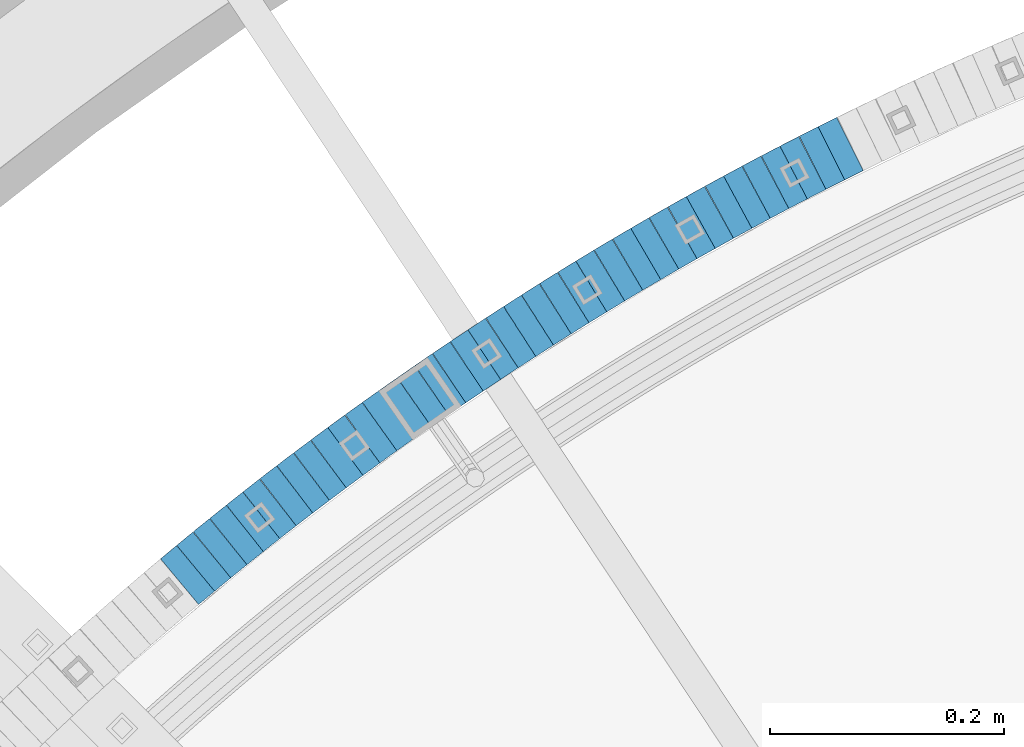
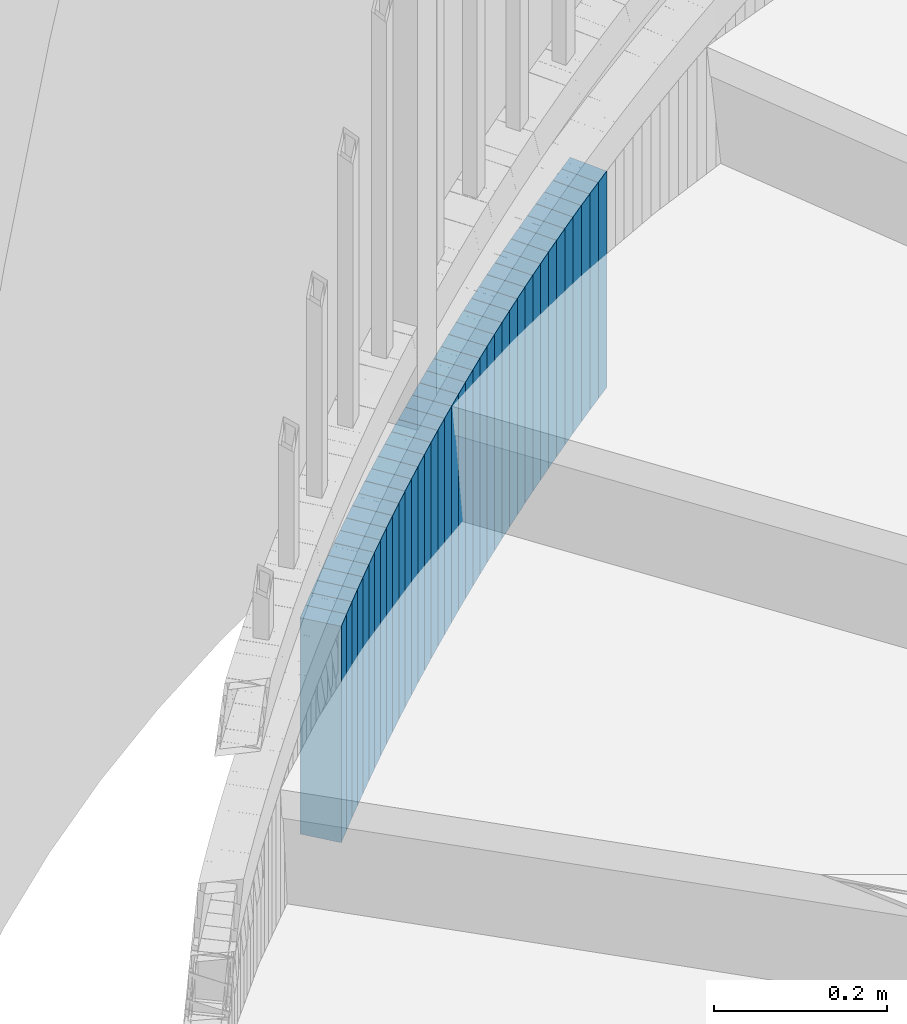
# One storey, part 893 of 975: 38 plates.
"""IFC2X3 building model written with IfcOpenShell, lengths in millimetres."""

from ifc_helpers import new_model, si_unit, frame, origin_with_axes, place, context, subcontext, project, spatial, faceted_brep, material, type_object, element, save


model = new_model("IFC2X3")

# Units and contexts
model_context = context("Model", 3, precision=1e-05, world=origin_with_axes())
body_context = subcontext(model_context, "Body", "Model", "MODEL_VIEW")
ifc_project = project(units=[si_unit("LENGTHUNIT", "METRE", prefix="MILLI"), si_unit("AREAUNIT", "SQUARE_METRE"), si_unit("VOLUMEUNIT", "CUBIC_METRE"), si_unit("MASSUNIT", "GRAM", prefix="KILO"), si_unit("TIMEUNIT", "SECOND"), si_unit("PLANEANGLEUNIT", "RADIAN"), si_unit("SOLIDANGLEUNIT", "STERADIAN"), si_unit("THERMODYNAMICTEMPERATUREUNIT", "DEGREE_CELSIUS"), si_unit("LUMINOUSINTENSITYUNIT", "LUMEN")], contexts=[model_context])

# Site, building, storey
site_placement = place(None, origin_with_axes())
site = spatial("IfcSite", under=ifc_project, at=site_placement, CompositionType="ELEMENT")
building_placement = place(site_placement, origin_with_axes())
building = spatial("IfcBuilding", under=site, at=building_placement, Name="Undefined", CompositionType="ELEMENT")
storey_placement = place(building_placement, origin_with_axes())
storey = spatial("IfcBuildingStorey", under=building, at=storey_placement, Name="Undefined", CompositionType="ELEMENT", Elevation=0.0)

# Plates
ifc_material = material(Name="STEEL/A36")
plate_type = type_object("IfcPlateType", PredefinedType="NOTDEFINED")
plate_1_placement = place(storey_placement, frame((33446.8379005465, 5969.29897554215, 642.299999991737), z_axis=(0.894427191057652, 0.447213595384486, -2.02726596398862e-10), x_axis=(0.0, 0.0, -1.0)))
element("IfcPlate", 1, at=plate_1_placement, inside=storey, type_object=plate_type, material=ifc_material, Name="WALL", context=body_context, shape_type="Brep", body=[
    faceted_brep([(0.0, -25.3999999999724, -1.81898940354586e-11), (-5.80000019073486, -25.4000000000378, 17.8932952880568), (-5.80000019073486, 25.4000000001179, 17.8932952881351), (0.0, 25.3999999999869, 1.45519152283669e-11), (299.0, -25.4000000000378, 17.8932952880568), (299.0, 25.4000000001179, 17.8932952881351), (304.799987792969, -25.3999999999724, -1.81898940354586e-11), (304.799987792969, 25.3999999999869, 1.45519152283669e-11)], [[[0, 1, 2, 3]], [[1, 4, 5, 2]], [[4, 6, 7, 5]], [[6, 0, 3, 7]], [[5, 7, 3, 2]], [[6, 4, 1, 0]]]),
])
for number, where, z_axis, x_axis, name in (
    (2, (33430.8379005525, 5961.29897554183, 636.599999991737), (0.894427191057652, 0.447213595384486, -2.02726596398862e-10), (0.0, 0.0, -1.0), "WALL"),
    (3, (33414.6548294389, 5952.95522164706, 630.899999991737), (0.88876758866203, 0.458358127825701, 0.0), (0.0, 0.0, -1.0), "WALL"),
):
    element("IfcPlate", number, at=place(storey_placement, frame(where, z_axis=z_axis, x_axis=x_axis)), inside=storey, type_object=plate_type, material=ifc_material, Name=name, context=body_context, shape_type="Brep", body=[
        faceted_brep([(0.0, -25.3999999999724, -1.81898940354586e-11), (-5.69999980926514, -25.4000000000087, 17.8910598754701), (-5.69999980926514, 25.4000000000087, 17.8910598755028), (0.0, 25.3999999999869, 1.45519152283669e-11), (299.100006103516, -25.4000000000087, 17.8910598754701), (299.100006103516, 25.4000000000087, 17.8910598755028), (304.799987792969, -25.3999999999724, -1.81898940354586e-11), (304.799987792969, 25.3999999999869, 1.45519152283669e-11)], [[[0, 1, 2, 3]], [[1, 4, 5, 2]], [[4, 6, 7, 5]], [[6, 0, 3, 7]], [[5, 7, 3, 2]], [[6, 4, 1, 0]]]),
    ])
plate_2_placement = place(storey_placement, frame((33398.7967408327, 5944.72516926029, 625.199999991737), z_axis=(0.887584423987997, 0.460645080614019, 2.15857426155708e-10), x_axis=(0.0, 0.0, -1.0)))
element("IfcPlate", 4, at=plate_2_placement, inside=storey, type_object=plate_type, material=ifc_material, Name="WALL", context=body_context, shape_type="Brep", body=[
    faceted_brep([(0.0, -25.3999999999724, -1.81898940354586e-11), (-5.69999980926514, -25.4000000000378, 17.8044929504049), (-5.69999980926514, 25.4000000000233, 17.8044929504613), (0.0, 25.3999999999869, 1.45519152283669e-11), (299.100006103516, -25.4000000000378, 17.8044929504049), (299.100006103516, 25.4000000000233, 17.8044929504613), (304.799987792969, -25.3999999999724, -1.81898940354586e-11), (304.799987792969, 25.3999999999869, 1.45519152283669e-11)], [[[0, 1, 2, 3]], [[1, 4, 5, 2]], [[4, 6, 7, 5]], [[6, 0, 3, 7]], [[5, 7, 3, 2]], [[6, 4, 1, 0]]]),
])
plate_3_placement = place(storey_placement, frame((33382.7736647993, 5936.20798742854, 619.399999991737), z_axis=(0.882970965834001, 0.469427601973053, -3.50903519574786e-11), x_axis=(0.0, 0.0, -1.0)))
element("IfcPlate", 5, at=plate_3_placement, inside=storey, type_object=plate_type, material=ifc_material, Name="WALL", context=body_context, shape_type="Brep", body=[
    faceted_brep([(0.0, -25.3999999999724, -1.81898940354586e-11), (-5.80000019073486, -25.4000000000378, 17.8932952880568), (-5.80000019073486, 25.4000000001179, 17.8932952881351), (0.0, 25.3999999999869, 1.45519152283669e-11), (299.0, -25.4000000000378, 17.8932952880568), (299.0, 25.4000000001179, 17.8932952881351), (304.799987792969, -25.3999999999724, -1.81898940354586e-11), (304.799987792969, 25.3999999999869, 1.45519152283669e-11)], [[[0, 1, 2, 3]], [[1, 4, 5, 2]], [[4, 6, 7, 5]], [[6, 0, 3, 7]], [[5, 7, 3, 2]], [[6, 4, 1, 0]]]),
])
for number, where, z_axis, x_axis, name in (
    (6, (33366.9041173823, 5927.617022949, 613.699999991737), (0.879389687135148, 0.476102697073169, 0.0), (0.0, 0.0, -1.0), "WALL"),
    (7, (33351.204117377, 5919.11702294876, 607.999999991737), (0.879389687135148, 0.476102697073169, 0.0), (0.0, 0.0, -1.0), "WALL"),
):
    element("IfcPlate", number, at=place(storey_placement, frame(where, z_axis=z_axis, x_axis=x_axis)), inside=storey, type_object=plate_type, material=ifc_material, Name=name, context=body_context, shape_type="Brep", body=[
        faceted_brep([(0.0, -25.3999999999724, -1.81898940354586e-11), (-5.69999980926514, -25.3999999999578, 17.853290557905), (-5.69999980926514, 25.4000000000124, 17.8532905578759), (0.0, 25.3999999999869, 1.45519152283669e-11), (299.100006103516, -25.3999999999578, 17.853290557905), (299.100006103516, 25.4000000000124, 17.8532905578759), (304.799987792969, -25.3999999999724, -1.81898940354586e-11), (304.799987792969, 25.3999999999869, 1.45519152283669e-11)], [[[0, 1, 2, 3]], [[1, 4, 5, 2]], [[4, 6, 7, 5]], [[6, 0, 3, 7]], [[5, 7, 3, 2]], [[6, 4, 1, 0]]]),
    ])
plate_4_placement = place(storey_placement, frame((33335.325590683, 5910.26396729605, 602.299999991737), z_axis=(0.87336387405012, 0.48706831502795, 0.0), x_axis=(0.0, 0.0, -1.0)))
element("IfcPlate", 8, at=plate_4_placement, inside=storey, type_object=plate_type, material=ifc_material, Name="WALL", context=body_context, shape_type="Brep", body=[
    faceted_brep([(0.0, -25.3999999999724, -1.81898940354586e-11), (-5.69999980926514, -25.3999999999687, 17.8619709015074), (-5.69999980926514, 25.4000000000415, 17.8619709015402), (0.0, 25.3999999999869, 1.45519152283669e-11), (299.100006103516, -25.3999999999687, 17.8619709015074), (299.100006103516, 25.4000000000415, 17.8619709015402), (304.799987792969, -25.3999999999724, -1.81898940354586e-11), (304.799987792969, 25.3999999999869, 1.45519152283669e-11)], [[[0, 1, 2, 3]], [[1, 4, 5, 2]], [[4, 6, 7, 5]], [[6, 0, 3, 7]], [[5, 7, 3, 2]], [[6, 4, 1, 0]]]),
])
plate_5_placement = place(storey_placement, frame((33319.7255906851, 5901.56396729572, 596.499999991737), z_axis=(0.87336387405012, 0.48706831502795, 0.0), x_axis=(0.0, 0.0, -1.0)))
element("IfcPlate", 9, at=plate_5_placement, inside=storey, type_object=plate_type, material=ifc_material, Name="WALL", context=body_context, shape_type="Brep", body=[
    faceted_brep([(0.0, -25.3999999999724, -1.81898940354586e-11), (-5.80000019073486, -25.3999999999978, 17.8619709014965), (-5.80000019073486, 25.4000000000524, 17.8619709015475), (0.0, 25.3999999999869, 1.45519152283669e-11), (299.0, -25.3999999999978, 17.8619709014965), (299.0, 25.4000000000524, 17.8619709015475), (304.799987792969, -25.3999999999724, -1.81898940354586e-11), (304.799987792969, 25.3999999999869, 1.45519152283669e-11)], [[[0, 1, 2, 3]], [[1, 4, 5, 2]], [[4, 6, 7, 5]], [[6, 0, 3, 7]], [[5, 7, 3, 2]], [[6, 4, 1, 0]]]),
])
plate_6_placement = place(storey_placement, frame((33303.9493116068, 5892.50761716658, 590.799999991737), z_axis=(0.86720835715133, 0.497945444086892, 0.0), x_axis=(0.0, 0.0, -1.0)))
element("IfcPlate", 10, at=plate_6_placement, inside=storey, type_object=plate_type, material=ifc_material, Name="WALL", context=body_context, shape_type="Brep", body=[
    faceted_brep([(0.0, -25.3999999999724, -1.81898940354586e-11), (-5.69999980926514, -25.4000000000524, 17.8734436034756), (-5.69999980926514, 25.4000000000888, 17.8734436035884), (0.0, 25.3999999999869, 1.45519152283669e-11), (299.100006103516, -25.4000000000524, 17.8734436034756), (299.100006103516, 25.4000000000888, 17.8734436035884), (304.799987792969, -25.3999999999724, -1.81898940354586e-11), (304.799987792969, 25.3999999999869, 1.45519152283669e-11)], [[[0, 1, 2, 3]], [[1, 4, 5, 2]], [[4, 6, 7, 5]], [[6, 0, 3, 7]], [[5, 7, 3, 2]], [[6, 4, 1, 0]]]),
])
plate_7_placement = place(storey_placement, frame((33288.3810982039, 5883.41017227856, 585.099999991737), z_axis=(0.863371944159825, 0.504568019237926, -8.114466254483e-11), x_axis=(0.0, 0.0, -1.0)))
element("IfcPlate", 11, at=plate_7_placement, inside=storey, type_object=plate_type, material=ifc_material, Name="WALL", context=body_context, shape_type="Brep", body=[
    faceted_brep([(0.0, -25.3999999999724, -1.81898940354586e-11), (-5.69999980926514, -25.3999999999614, 17.8370399475461), (-5.69999980926514, 25.4000000000487, 17.8370399475571), (0.0, 25.3999999999869, 1.45519152283669e-11), (299.100006103516, -25.3999999999614, 17.8370399475461), (299.100006103516, 25.4000000000487, 17.8370399475571), (304.799987792969, -25.3999999999724, -1.81898940354586e-11), (304.799987792969, 25.3999999999869, 1.45519152283669e-11)], [[[0, 1, 2, 3]], [[1, 4, 5, 2]], [[4, 6, 7, 5]], [[6, 0, 3, 7]], [[5, 7, 3, 2]], [[6, 4, 1, 0]]]),
])
plate_8_placement = place(storey_placement, frame((33272.981098207, 5874.41017227898, 579.299999991737), z_axis=(0.863371944159825, 0.504568019237926, -8.114466254483e-11), x_axis=(0.0, 0.0, -1.0)))
element("IfcPlate", 12, at=plate_8_placement, inside=storey, type_object=plate_type, material=ifc_material, Name="WALL", context=body_context, shape_type="Brep", body=[
    faceted_brep([(0.0, -25.3999999999724, -1.81898940354586e-11), (-5.80000019073486, -25.3999999999578, 17.8370399475461), (-5.80000019073486, 25.4000000000524, 17.8370399475607), (0.0, 25.3999999999869, 1.45519152283669e-11), (299.0, -25.3999999999578, 17.8370399475461), (299.0, 25.4000000000524, 17.8370399475607), (304.799987792969, -25.3999999999724, -1.81898940354586e-11), (304.799987792969, 25.3999999999869, 1.45519152283669e-11)], [[[0, 1, 2, 3]], [[1, 4, 5, 2]], [[4, 6, 7, 5]], [[6, 0, 3, 7]], [[5, 7, 3, 2]], [[6, 4, 1, 0]]]),
])
plate_9_placement = place(storey_placement, frame((33257.3706024892, 5865.08579233509, 573.599999991737), z_axis=(0.858475095883078, 0.512855252238427, -1.68183078130824e-10), x_axis=(0.0, 0.0, -1.0)))
element("IfcPlate", 13, at=plate_9_placement, inside=storey, type_object=plate_type, material=ifc_material, Name="WALL", context=body_context, shape_type="Brep", body=[
    faceted_brep([(0.0, -25.3999999999724, -1.81898940354586e-11), (-5.69999980926514, -25.399999999885, 17.9387855530204), (-5.69999980926514, 25.3999999999651, 17.9387855529603), (0.0, 25.3999999999869, 1.45519152283669e-11), (299.100006103516, -25.399999999885, 17.9387855530204), (299.100006103516, 25.3999999999651, 17.9387855529603), (304.799987792969, -25.3999999999724, -1.81898940354586e-11), (304.799987792969, 25.3999999999869, 1.45519152283669e-11)], [[[0, 1, 2, 3]], [[1, 4, 5, 2]], [[4, 6, 7, 5]], [[6, 0, 3, 7]], [[5, 7, 3, 2]], [[6, 4, 1, 0]]]),
])
plate_10_placement = place(storey_placement, frame((33241.9039773167, 5855.68538220351, 567.899999991737), z_axis=(0.854521941236345, 0.519415298143661, 0.0), x_axis=(0.0, 0.0, -1.0)))
element("IfcPlate", 14, at=plate_10_placement, inside=storey, type_object=plate_type, material=ifc_material, Name="WALL", context=body_context, shape_type="Brep", body=[
    faceted_brep([(0.0, -25.3999999999724, -1.81898940354586e-11), (-5.69999980926514, -25.3999999999578, 17.9047489166387), (-5.69999980926514, 25.3999999999069, 17.9047489165732), (0.0, 25.3999999999869, 1.45519152283669e-11), (299.100006103516, -25.3999999999578, 17.9047489166387), (299.100006103516, 25.3999999999069, 17.9047489165732), (304.799987792969, -25.3999999999724, -1.81898940354586e-11), (304.799987792969, 25.3999999999869, 1.45519152283669e-11)], [[[0, 1, 2, 3]], [[1, 4, 5, 2]], [[4, 6, 7, 5]], [[6, 0, 3, 7]], [[5, 7, 3, 2]], [[6, 4, 1, 0]]]),
])
plate_11_placement = place(storey_placement, frame((33226.6407660649, 5846.34683340255, 562.099999991737), z_axis=(0.853004272179022, 0.521903929516091, -1.64764969667885e-10), x_axis=(0.0, 0.0, -1.0)))
element("IfcPlate", 15, at=plate_11_placement, inside=storey, type_object=plate_type, material=ifc_material, Name="WALL", context=body_context, shape_type="Brep", body=[
    faceted_brep([(0.0, -25.3999999999724, -1.81898940354586e-11), (-5.80000019073486, -25.400000000016, 17.8193721771022), (-5.80000019073486, 25.4000000001179, 17.8193721772113), (0.0, 25.3999999999869, 1.45519152283669e-11), (299.0, -25.400000000016, 17.8193721771022), (299.0, 25.4000000001179, 17.8193721772113), (304.799987792969, -25.3999999999724, -1.81898940354586e-11), (304.799987792969, 25.3999999999869, 1.45519152283669e-11)], [[[0, 1, 2, 3]], [[1, 4, 5, 2]], [[4, 6, 7, 5]], [[6, 0, 3, 7]], [[5, 7, 3, 2]], [[6, 4, 1, 0]]]),
])
plate_12_placement = place(storey_placement, frame((33211.2351528119, 5836.71968181761, 556.399999991737), z_axis=(0.847998304005088, 0.529998940003181, 0.0), x_axis=(0.0, 0.0, -1.0)))
element("IfcPlate", 16, at=plate_12_placement, inside=storey, type_object=plate_type, material=ifc_material, Name="WALL", context=body_context, shape_type="Brep", body=[
    faceted_brep([(0.0, -25.3999999999724, -1.81898940354586e-11), (-5.69999980926514, -25.4000000000087, 17.9245643615468), (-5.69999980926514, 25.3999999999687, 17.9245643615541), (0.0, 25.3999999999869, 1.45519152283669e-11), (299.100006103516, -25.4000000000087, 17.9245643615468), (299.100006103516, 25.3999999999687, 17.9245643615541), (304.799987792969, -25.3999999999724, -1.81898940354586e-11), (304.799987792969, 25.3999999999869, 1.45519152283669e-11)], [[[0, 1, 2, 3]], [[1, 4, 5, 2]], [[4, 6, 7, 5]], [[6, 0, 3, 7]], [[5, 7, 3, 2]], [[6, 4, 1, 0]]]),
])
plate_13_placement = place(storey_placement, frame((33195.969674812, 5827.01536982686, 550.599999991737), z_axis=(0.843891532718926, 0.536513821821304, 0.0), x_axis=(0.0, 0.0, -1.0)))
element("IfcPlate", 17, at=plate_13_placement, inside=storey, type_object=plate_type, material=ifc_material, Name="WALL", context=body_context, shape_type="Brep", body=[
    faceted_brep([(0.0, -25.3999999999724, -1.81898940354586e-11), (-5.80000019073486, -25.4000000000378, 17.8932952880568), (-5.80000019073486, 25.4000000001179, 17.8932952881351), (0.0, 25.3999999999869, 1.45519152283669e-11), (299.0, -25.4000000000378, 17.8932952880568), (299.0, 25.4000000001179, 17.8932952881351), (304.799987792969, -25.3999999999724, -1.81898940354586e-11), (304.799987792969, 25.3999999999869, 1.45519152283669e-11)], [[[0, 1, 2, 3]], [[1, 4, 5, 2]], [[4, 6, 7, 5]], [[6, 0, 3, 7]], [[5, 7, 3, 2]], [[6, 4, 1, 0]]]),
])
plate_14_placement = place(storey_placement, frame((33180.769036802, 5817.25105531003, 544.899999991737), z_axis=(0.84135946512133, 0.540475948077942, 0.0), x_axis=(0.0, 0.0, -1.0)))
element("IfcPlate", 18, at=plate_14_placement, inside=storey, type_object=plate_type, material=ifc_material, Name="WALL", context=body_context, shape_type="Brep", body=[
    faceted_brep([(0.0, -25.3999999999724, -1.81898940354586e-11), (-5.69999980926514, -25.4000000000087, 17.9493732452502), (-5.69999980926514, 25.3999999999905, 17.9493732452102), (0.0, 25.3999999999869, 1.45519152283669e-11), (299.100006103516, -25.4000000000087, 17.9493732452502), (299.100006103516, 25.3999999999905, 17.9493732452102), (304.799987792969, -25.3999999999724, -1.81898940354586e-11), (304.799987792969, 25.3999999999869, 1.45519152283669e-11)], [[[0, 1, 2, 3]], [[1, 4, 5, 2]], [[4, 6, 7, 5]], [[6, 0, 3, 7]], [[5, 7, 3, 2]], [[6, 4, 1, 0]]]),
])
plate_15_placement = place(storey_placement, frame((33165.7044397314, 5807.50942099266, 539.199999991737), z_axis=(0.83972031877, 0.543019139851267, 0.0), x_axis=(0.0, 0.0, -1.0)))
element("IfcPlate", 19, at=plate_15_placement, inside=storey, type_object=plate_type, material=ifc_material, Name="WALL", context=body_context, shape_type="Brep", body=[
    faceted_brep([(0.0, -25.3999999999724, -1.81898940354586e-11), (-5.69999980926514, -25.3999999999687, 17.8619709015074), (-5.69999980926514, 25.4000000000415, 17.8619709015402), (0.0, 25.3999999999869, 1.45519152283669e-11), (299.100006103516, -25.3999999999687, 17.8619709015074), (299.100006103516, 25.4000000000415, 17.8619709015402), (304.799987792969, -25.3999999999724, -1.81898940354586e-11), (304.799987792969, 25.3999999999869, 1.45519152283669e-11)], [[[0, 1, 2, 3]], [[1, 4, 5, 2]], [[4, 6, 7, 5]], [[6, 0, 3, 7]], [[5, 7, 3, 2]], [[6, 4, 1, 0]]]),
])
plate_16_placement = place(storey_placement, frame((33150.5057338021, 5797.47960382964, 533.399999991737), z_axis=(0.834609406352343, 0.550842208647984, 2.89660420094152e-10), x_axis=(0.0, 0.0, -1.0)))
element("IfcPlate", 20, at=plate_16_placement, inside=storey, type_object=plate_type, material=ifc_material, Name="WALL", context=body_context, shape_type="Brep", body=[
    faceted_brep([(0.0, -25.3999999999724, -1.81898940354586e-11), (-5.80000019073486, -25.4000000000051, 17.9724788665662), (-5.80000019073486, 25.4000000000196, 17.9724788666281), (0.0, 25.3999999999869, 1.45519152283669e-11), (299.0, -25.4000000000051, 17.9724788665662), (299.0, 25.4000000000196, 17.9724788666281), (304.799987792969, -25.3999999999724, -1.81898940354586e-11), (304.799987792969, 25.3999999999869, 1.45519152283669e-11)], [[[0, 1, 2, 3]], [[1, 4, 5, 2]], [[4, 6, 7, 5]], [[6, 0, 3, 7]], [[5, 7, 3, 2]], [[6, 4, 1, 0]]]),
])
plate_17_placement = place(storey_placement, frame((33135.5405238058, 5787.53642095245, 527.599999991737), z_axis=(0.832909293569711, 0.553409530714104, 0.0), x_axis=(0.0, 0.0, -1.0)))
element("IfcPlate", 21, at=plate_17_placement, inside=storey, type_object=plate_type, material=ifc_material, Name="WALL", context=body_context, shape_type="Brep", body=[
    faceted_brep([(0.0, -25.3999999999724, -1.81898940354586e-11), (-5.80000019073486, -25.4000000000378, 17.8932952880568), (-5.80000019073486, 25.4000000001179, 17.8932952881351), (0.0, 25.3999999999869, 1.45519152283669e-11), (299.0, -25.4000000000378, 17.8932952880568), (299.0, 25.4000000001179, 17.8932952881351), (304.799987792969, -25.3999999999724, -1.81898940354586e-11), (304.799987792969, 25.3999999999869, 1.45519152283669e-11)], [[[0, 1, 2, 3]], [[1, 4, 5, 2]], [[4, 6, 7, 5]], [[6, 0, 3, 7]], [[5, 7, 3, 2]], [[6, 4, 1, 0]]]),
])
plate_18_placement = place(storey_placement, frame((33120.5424790931, 5777.47094864982, 521.899999991737), z_axis=(0.830331643827375, 0.557269558884145, 0.0), x_axis=(0.0, 0.0, -1.0)))
element("IfcPlate", 22, at=plate_18_placement, inside=storey, type_object=plate_type, material=ifc_material, Name="WALL", context=body_context, shape_type="Brep", body=[
    faceted_brep([(0.0, -25.3999999999724, -1.81898940354586e-11), (-5.69999980926514, -25.399999999885, 17.9387855530204), (-5.69999980926514, 25.3999999999651, 17.9387855529603), (0.0, 25.3999999999869, 1.45519152283669e-11), (299.100006103516, -25.399999999885, 17.9387855530204), (299.100006103516, 25.3999999999651, 17.9387855529603), (304.799987792969, -25.3999999999724, -1.81898940354586e-11), (304.799987792969, 25.3999999999869, 1.45519152283669e-11)], [[[0, 1, 2, 3]], [[1, 4, 5, 2]], [[4, 6, 7, 5]], [[6, 0, 3, 7]], [[5, 7, 3, 2]], [[6, 4, 1, 0]]]),
])
plate_19_placement = place(storey_placement, frame((33105.5795744149, 5767.26069934168, 516.199999991737), z_axis=(0.825991119591471, 0.56368312938745, 1.78134541783948e-10), x_axis=(0.0, 0.0, -1.0)))
element("IfcPlate", 23, at=plate_19_placement, inside=storey, type_object=plate_type, material=ifc_material, Name="WALL", context=body_context, shape_type="Brep", body=[
    faceted_brep([(0.0, -25.3999999999724, -1.81898940354586e-11), (-5.69999980926514, -25.4000000000087, 17.9245643615468), (-5.69999980926514, 25.3999999999687, 17.9245643615541), (0.0, 25.3999999999869, 1.45519152283669e-11), (299.100006103516, -25.4000000000087, 17.9245643615468), (299.100006103516, 25.3999999999687, 17.9245643615541), (304.799987792969, -25.3999999999724, -1.81898940354586e-11), (304.799987792969, 25.3999999999869, 1.45519152283669e-11)], [[[0, 1, 2, 3]], [[1, 4, 5, 2]], [[4, 6, 7, 5]], [[6, 0, 3, 7]], [[5, 7, 3, 2]], [[6, 4, 1, 0]]]),
])
plate_20_placement = place(storey_placement, frame((33090.7170545739, 5756.94886298745, 510.399999991737), z_axis=(0.821588113548792, 0.570081548267734, 1.52022039401345e-10), x_axis=(0.0, 0.0, -1.0)))
element("IfcPlate", 24, at=plate_20_placement, inside=storey, type_object=plate_type, material=ifc_material, Name="WALL", context=body_context, shape_type="Brep", body=[
    faceted_brep([(0.0, -25.3999999999724, -1.81898940354586e-11), (-5.80000019073486, -25.4000000000378, 17.8932952880568), (-5.80000019073486, 25.4000000001179, 17.8932952881351), (0.0, 25.3999999999869, 1.45519152283669e-11), (299.0, -25.4000000000378, 17.8932952880568), (299.0, 25.4000000001179, 17.8932952881351), (304.799987792969, -25.3999999999724, -1.81898940354586e-11), (304.799987792969, 25.3999999999869, 1.45519152283669e-11)], [[[0, 1, 2, 3]], [[1, 4, 5, 2]], [[4, 6, 7, 5]], [[6, 0, 3, 7]], [[5, 7, 3, 2]], [[6, 4, 1, 0]]]),
])
plate_21_placement = place(storey_placement, frame((33075.9216866142, 5746.58236543765, 504.699999991737), z_axis=(0.818970100023311, 0.573836192016335, 0.0), x_axis=(0.0, 0.0, -1.0)))
element("IfcPlate", 25, at=plate_21_placement, inside=storey, type_object=plate_type, material=ifc_material, Name="WALL", context=body_context, shape_type="Brep", body=[
    faceted_brep([(0.0, -25.3999999999724, -1.81898940354586e-11), (-5.69999980926514, -25.4000000000087, 17.9493732452502), (-5.69999980926514, 25.3999999999905, 17.9493732452102), (0.0, 25.3999999999869, 1.45519152283669e-11), (299.100006103516, -25.4000000000087, 17.9493732452502), (299.100006103516, 25.3999999999905, 17.9493732452102), (304.799987792969, -25.3999999999724, -1.81898940354586e-11), (304.799987792969, 25.3999999999869, 1.45519152283669e-11)], [[[0, 1, 2, 3]], [[1, 4, 5, 2]], [[4, 6, 7, 5]], [[6, 0, 3, 7]], [[5, 7, 3, 2]], [[6, 4, 1, 0]]]),
])
plate_22_placement = place(storey_placement, frame((33061.1604959829, 5736.06848610545, 498.899999991737), z_axis=(0.814486661793431, 0.580182279771275, -2.11284714168869e-11), x_axis=(0.0, 0.0, -1.0)))
element("IfcPlate", 26, at=plate_22_placement, inside=storey, type_object=plate_type, material=ifc_material, Name="WALL", context=body_context, shape_type="Brep", body=[
    faceted_brep([(0.0, -25.3999999999724, -1.81898940354586e-11), (-5.80000019073486, -25.3999999998778, 17.9254016876821), (-5.80000019073486, 25.3999999999651, 17.9254016876057), (0.0, 25.3999999999869, 1.45519152283669e-11), (299.0, -25.3999999998778, 17.9254016876821), (299.0, 25.3999999999651, 17.9254016876057), (304.799987792969, -25.3999999999724, -1.81898940354586e-11), (304.799987792969, 25.3999999999869, 1.45519152283669e-11)], [[[0, 1, 2, 3]], [[1, 4, 5, 2]], [[4, 6, 7, 5]], [[6, 0, 3, 7]], [[5, 7, 3, 2]], [[6, 4, 1, 0]]]),
])
plate_23_placement = place(storey_placement, frame((33046.5933089394, 5725.62046200203, 493.199999991737), z_axis=(0.812595948879356, 0.582827439183211, 7.00165401212871e-11), x_axis=(0.0, 0.0, -1.0)))
element("IfcPlate", 27, at=plate_23_placement, inside=storey, type_object=plate_type, material=ifc_material, Name="WALL", context=body_context, shape_type="Brep", body=[
    faceted_brep([(0.0, -25.3999999999724, -1.81898940354586e-11), (-5.69999980926514, -25.3999999999614, 17.8370399475461), (-5.69999980926514, 25.4000000000487, 17.8370399475571), (0.0, 25.3999999999869, 1.45519152283669e-11), (299.100006103516, -25.3999999999614, 17.8370399475461), (299.100006103516, 25.4000000000487, 17.8370399475571), (304.799987792969, -25.3999999999724, -1.81898940354586e-11), (304.799987792969, 25.3999999999869, 1.45519152283669e-11)], [[[0, 1, 2, 3]], [[1, 4, 5, 2]], [[4, 6, 7, 5]], [[6, 0, 3, 7]], [[5, 7, 3, 2]], [[6, 4, 1, 0]]]),
])
plate_24_placement = place(storey_placement, frame((33031.9395632156, 5714.83608175507, 487.499999991737), z_axis=(0.805336884073592, 0.592817428177207, 3.1585841497872e-11), x_axis=(0.0, 0.0, -1.0)))
element("IfcPlate", 28, at=plate_24_placement, inside=storey, type_object=plate_type, material=ifc_material, Name="WALL", context=body_context, shape_type="Brep", body=[
    faceted_brep([(0.0, -25.3999999999724, -1.81898940354586e-11), (-5.69999980926514, -25.4000000000233, 17.8807163238162), (-5.69999980926514, 25.400000000096, 17.8807163239253), (0.0, 25.3999999999869, 1.45519152283669e-11), (299.100006103516, -25.4000000000233, 17.8807163238162), (299.100006103516, 25.400000000096, 17.8807163239253), (304.799987792969, -25.3999999999724, -1.81898940354586e-11), (304.799987792969, 25.3999999999869, 1.45519152283669e-11)], [[[0, 1, 2, 3]], [[1, 4, 5, 2]], [[4, 6, 7, 5]], [[6, 0, 3, 7]], [[5, 7, 3, 2]], [[6, 4, 1, 0]]]),
])
plate_25_placement = place(storey_placement, frame((33017.5395632147, 5704.23608175464, 481.699999991737), z_axis=(0.805336884073592, 0.592817428177207, 3.1585841497872e-11), x_axis=(0.0, 0.0, -1.0)))
element("IfcPlate", 29, at=plate_25_placement, inside=storey, type_object=plate_type, material=ifc_material, Name="WALL", context=body_context, shape_type="Brep", body=[
    faceted_brep([(0.0, -25.3999999999724, -1.81898940354586e-11), (-5.80000019073486, -25.4000000000415, 17.8751220702761), (-5.80000019073486, 25.4000000000015, 17.8751220703089), (0.0, 25.3999999999869, 1.45519152283669e-11), (299.0, -25.4000000000415, 17.8751220702761), (299.0, 25.4000000000015, 17.8751220703089), (304.799987792969, -25.3999999999724, -1.81898940354586e-11), (304.799987792969, 25.3999999999869, 1.45519152283669e-11)], [[[0, 1, 2, 3]], [[1, 4, 5, 2]], [[4, 6, 7, 5]], [[6, 0, 3, 7]], [[5, 7, 3, 2]], [[6, 4, 1, 0]]]),
])
plate_26_placement = place(storey_placement, frame((33003.0798901761, 5693.41757820775, 475.999999991737), z_axis=(0.800671390161604, 0.59910376812092, 0.0), x_axis=(0.0, 0.0, -1.0)))
element("IfcPlate", 30, at=plate_26_placement, inside=storey, type_object=plate_type, material=ifc_material, Name="WALL", context=body_context, shape_type="Brep", body=[
    faceted_brep([(0.0, -25.3999999999724, -1.81898940354586e-11), (-5.69999980926514, -25.3999999999687, 17.8619709015074), (-5.69999980926514, 25.4000000000415, 17.8619709015402), (0.0, 25.3999999999869, 1.45519152283669e-11), (299.100006103516, -25.3999999999687, 17.8619709015074), (299.100006103516, 25.4000000000415, 17.8619709015402), (304.799987792969, -25.3999999999724, -1.81898940354586e-11), (304.799987792969, 25.3999999999869, 1.45519152283669e-11)], [[[0, 1, 2, 3]], [[1, 4, 5, 2]], [[4, 6, 7, 5]], [[6, 0, 3, 7]], [[5, 7, 3, 2]], [[6, 4, 1, 0]]]),
])
plate_27_placement = place(storey_placement, frame((32988.7207921184, 5682.49755632707, 470.299999991737), z_axis=(0.795946119280133, 0.605367471213061, 0.0), x_axis=(0.0, 0.0, -1.0)))
element("IfcPlate", 31, at=plate_27_placement, inside=storey, type_object=plate_type, material=ifc_material, Name="WALL", context=body_context, shape_type="Brep", body=[
    faceted_brep([(0.0, -25.3999999999724, -1.81898940354586e-11), (-5.69999980926514, -25.3999999999614, 17.8370399475461), (-5.69999980926514, 25.4000000000487, 17.8370399475571), (0.0, 25.3999999999869, 1.45519152283669e-11), (299.100006103516, -25.3999999999614, 17.8370399475461), (299.100006103516, 25.4000000000487, 17.8370399475571), (304.799987792969, -25.3999999999724, -1.81898940354586e-11), (304.799987792969, 25.3999999999869, 1.45519152283669e-11)], [[[0, 1, 2, 3]], [[1, 4, 5, 2]], [[4, 6, 7, 5]], [[6, 0, 3, 7]], [[5, 7, 3, 2]], [[6, 4, 1, 0]]]),
])
plate_28_placement = place(storey_placement, frame((32974.4310521367, 5671.52898793627, 464.499999991737), z_axis=(0.793246576330856, 0.608900541253968, 0.0), x_axis=(0.0, 0.0, -1.0)))
element("IfcPlate", 32, at=plate_28_placement, inside=storey, type_object=plate_type, material=ifc_material, Name="WALL", context=body_context, shape_type="Brep", body=[
    faceted_brep([(0.0, -25.3999999999724, -1.81898940354586e-11), (-5.80000019073486, -25.3999999999614, 17.8966484070224), (-5.80000019073486, 25.3999999999105, 17.896648406906), (0.0, 25.3999999999869, 1.45519152283669e-11), (299.0, -25.3999999999614, 17.8966484070224), (299.0, 25.3999999999105, 17.896648406906), (304.799987792969, -25.3999999999724, -1.81898940354586e-11), (304.799987792969, 25.3999999999869, 1.45519152283669e-11)], [[[0, 1, 2, 3]], [[1, 4, 5, 2]], [[4, 6, 7, 5]], [[6, 0, 3, 7]], [[5, 7, 3, 2]], [[6, 4, 1, 0]]]),
])
plate_29_placement = place(storey_placement, frame((32960.2044584691, 5660.35301070426, 458.799999991737), z_axis=(0.786318338803167, 0.61782155195641, -5.59168711333768e-11), x_axis=(0.0, 0.0, -1.0)))
element("IfcPlate", 33, at=plate_29_placement, inside=storey, type_object=plate_type, material=ifc_material, Name="WALL", context=body_context, shape_type="Brep", body=[
    faceted_brep([(0.0, -25.3999999999724, -1.81898940354586e-11), (-5.69999980926514, -25.4000000000378, 17.8044929504049), (-5.69999980926514, 25.4000000000233, 17.8044929504613), (0.0, 25.3999999999869, 1.45519152283669e-11), (299.100006103516, -25.4000000000378, 17.8044929504049), (299.100006103516, 25.4000000000233, 17.8044929504613), (304.799987792969, -25.3999999999724, -1.81898940354586e-11), (304.799987792969, 25.3999999999869, 1.45519152283669e-11)], [[[0, 1, 2, 3]], [[1, 4, 5, 2]], [[4, 6, 7, 5]], [[6, 0, 3, 7]], [[5, 7, 3, 2]], [[6, 4, 1, 0]]]),
])
plate_30_placement = place(storey_placement, frame((32946.116709769, 5649.18375245434, 453.099999991737), z_axis=(0.783591636094263, 0.621276225074738, 0.0), x_axis=(0.0, 0.0, -1.0)))
element("IfcPlate", 34, at=plate_30_placement, inside=storey, type_object=plate_type, material=ifc_material, Name="WALL", context=body_context, shape_type="Brep", body=[
    faceted_brep([(0.0, -25.3999999999724, -1.81898940354586e-11), (-5.69999980926514, -25.4000000000524, 17.8734436034756), (-5.69999980926514, 25.4000000000888, 17.8734436035884), (0.0, 25.3999999999869, 1.45519152283669e-11), (299.100006103516, -25.4000000000524, 17.8734436034756), (299.100006103516, 25.4000000000888, 17.8734436035884), (304.799987792969, -25.3999999999724, -1.81898940354586e-11), (304.799987792969, 25.3999999999869, 1.45519152283669e-11)], [[[0, 1, 2, 3]], [[1, 4, 5, 2]], [[4, 6, 7, 5]], [[6, 0, 3, 7]], [[5, 7, 3, 2]], [[6, 4, 1, 0]]]),
])
plate_31_placement = place(storey_placement, frame((32932.0298716638, 5637.91459264769, 447.399999991737), z_axis=(0.78086880941289, 0.6246950475921, 3.66534777640482e-10), x_axis=(0.0, 0.0, -1.0)))
element("IfcPlate", 35, at=plate_31_placement, inside=storey, type_object=plate_type, material=ifc_material, Name="WALL", context=body_context, shape_type="Brep", body=[
    faceted_brep([(0.0, -25.3999999999724, -1.81898940354586e-11), (-5.69999980926514, -25.3999999999942, 17.9287471771386), (-5.69999980926514, 25.3999999999796, 17.9287471770876), (0.0, 25.3999999999869, 1.45519152283669e-11), (299.100006103516, -25.3999999999942, 17.9287471771386), (299.100006103516, 25.3999999999796, 17.9287471770876), (304.799987792969, -25.3999999999724, -1.81898940354586e-11), (304.799987792969, 25.3999999999869, 1.45519152283669e-11)], [[[0, 1, 2, 3]], [[1, 4, 5, 2]], [[4, 6, 7, 5]], [[6, 0, 3, 7]], [[5, 7, 3, 2]], [[6, 4, 1, 0]]]),
])
plate_32_placement = place(storey_placement, frame((32918.0908361194, 5626.60256049365, 441.599999991737), z_axis=(0.776458094254318, 0.630168888367993, -8.04775481810794e-11), x_axis=(0.0, 0.0, -1.0)))
element("IfcPlate", 36, at=plate_32_placement, inside=storey, type_object=plate_type, material=ifc_material, Name="WALL", context=body_context, shape_type="Brep", body=[
    faceted_brep([(0.0, -25.3999999999724, -1.81898940354586e-11), (-5.80000019073486, -25.400000000016, 17.7730140686072), (-5.80000019073486, 25.4000000000742, 17.7730140686326), (0.0, 25.3999999999869, 1.45519152283669e-11), (299.0, -25.400000000016, 17.7730140686072), (299.0, 25.4000000000742, 17.7730140686326), (304.799987792969, -25.3999999999724, -1.81898940354586e-11), (304.799987792969, 25.3999999999869, 1.45519152283669e-11)], [[[0, 1, 2, 3]], [[1, 4, 5, 2]], [[4, 6, 7, 5]], [[6, 0, 3, 7]], [[5, 7, 3, 2]], [[6, 4, 1, 0]]]),
])
plate_33_placement = place(storey_placement, frame((32904.1203371346, 5615.06295339364, 435.899999991737), z_axis=(0.77096175158008, 0.636881447053198, -1.96447672351497e-10), x_axis=(0.0, 0.0, -1.0)))
element("IfcPlate", 37, at=plate_33_placement, inside=storey, type_object=plate_type, material=ifc_material, Name="WALL", context=body_context, shape_type="Brep", body=[
    faceted_brep([(0.0, -25.3999999999724, -1.81898940354586e-11), (-5.69999980926514, -25.3999999999578, 17.9047489166387), (-5.69999980926514, 25.3999999999069, 17.9047489165732), (0.0, 25.3999999999869, 1.45519152283669e-11), (299.100006103516, -25.3999999999578, 17.9047489166387), (299.100006103516, 25.3999999999069, 17.9047489165732), (304.799987792969, -25.3999999999724, -1.81898940354586e-11), (304.799987792969, 25.3999999999869, 1.45519152283669e-11)], [[[0, 1, 2, 3]], [[1, 4, 5, 2]], [[4, 6, 7, 5]], [[6, 0, 3, 7]], [[5, 7, 3, 2]], [[6, 4, 1, 0]]]),
])
plate_34_placement = place(storey_placement, frame((32890.350464151, 5603.6050218839, 430.199999991737), z_axis=(0.768680983658604, 0.639632351715922, 0.0), x_axis=(0.0, 0.0, -1.0)))
element("IfcPlate", 38, at=plate_34_placement, inside=storey, type_object=plate_type, material=ifc_material, Name="WALL", context=body_context, shape_type="Brep", body=[
    faceted_brep([(0.0, -25.3999999999724, -1.81898940354586e-11), (-5.69999980926514, -25.4000000000669, 17.8227386474155), (-5.69999980926514, 25.3999999999724, 17.8227386474609), (0.0, 25.3999999999869, 1.45519152283669e-11), (299.100006103516, -25.4000000000669, 17.8227386474155), (299.100006103516, 25.3999999999724, 17.8227386474609), (304.799987792969, -25.3999999999724, -1.81898940354586e-11), (304.799987792969, 25.3999999999869, 1.45519152283669e-11)], [[[0, 1, 2, 3]], [[1, 4, 5, 2]], [[4, 6, 7, 5]], [[6, 0, 3, 7]], [[5, 7, 3, 2]], [[6, 4, 1, 0]]]),
])

save(model, "model.ifc")
